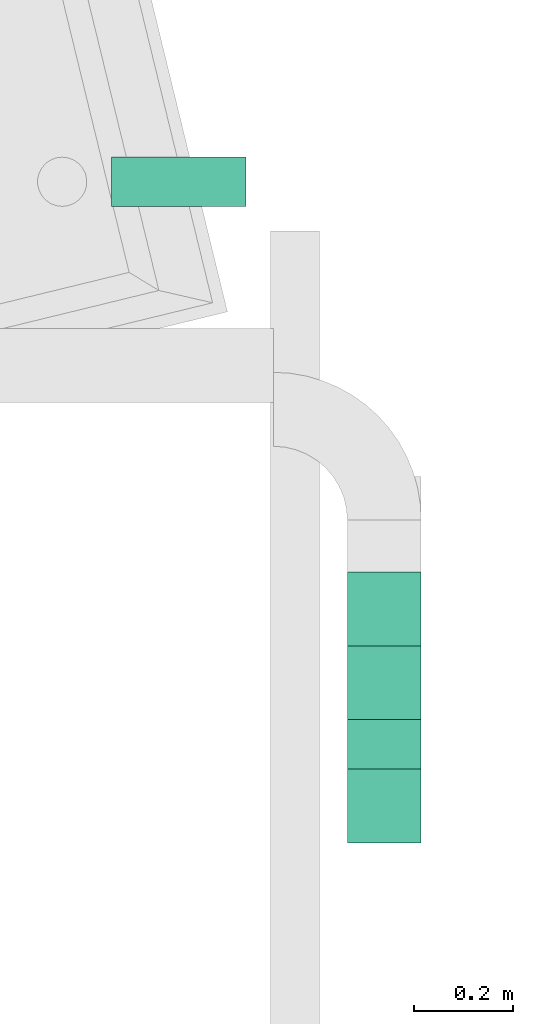
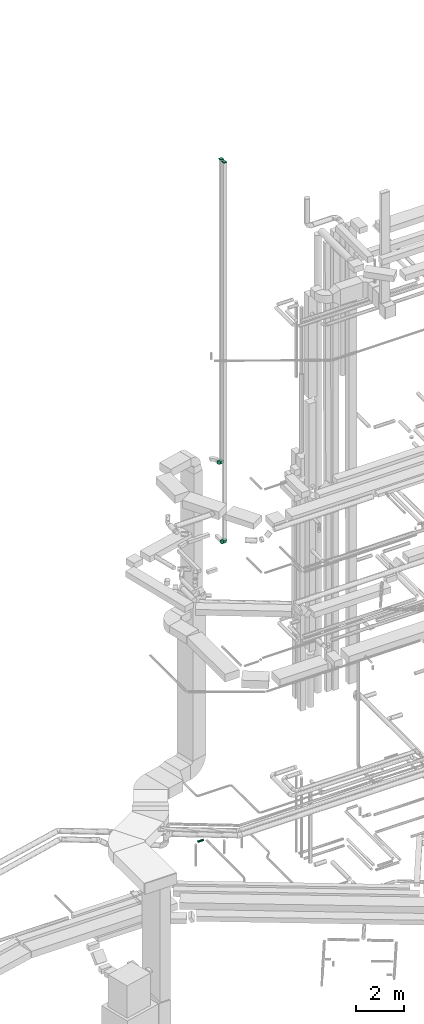
# One storey, part 91 of 337: 4 flow fittings, 1 flow segment.
"""IFC2X3 building model written with IfcOpenShell, lengths in millimetres."""

from ifc_helpers import new_model, entity, si_unit, converted_unit, derived_unit, direction, frame, frame_2d, origin, origin_2d_with_axis, place, context, subcontext, project, spatial, polyline, circle_curve, parameter, trimmed, segment, composite_curve, rectangle, circle, outline, extrude, source, transform, mapped, material, type_object, type_shapes, element, save


model = new_model("IFC2X3")

# Units and contexts
model_context = context("Model", 3, precision=0.01, world=origin(), true_north=direction((6.12303176911189e-17, 1.0)))
body_context = subcontext(model_context, "Body", "Model", "MODEL_VIEW")
ifc_project = project(units=[si_unit("LENGTHUNIT", "METRE", prefix="MILLI"), si_unit("AREAUNIT", "SQUARE_METRE"), si_unit("VOLUMEUNIT", "CUBIC_METRE"), converted_unit("PLANEANGLEUNIT", "DEGREE", entity("IfcRatioMeasure", 0.0174532925199433), si_unit("PLANEANGLEUNIT", "RADIAN"), dimensions=[0, 0, 0, 0, 0, 0, 0]), si_unit("MASSUNIT", "GRAM", prefix="KILO"), derived_unit("MASSDENSITYUNIT", [(si_unit("MASSUNIT", "GRAM", prefix="KILO"), 1), (si_unit("LENGTHUNIT", "METRE"), -3)]), derived_unit("MOMENTOFINERTIAUNIT", [(si_unit("LENGTHUNIT", "METRE"), 4)]), si_unit("TIMEUNIT", "SECOND"), si_unit("FREQUENCYUNIT", "HERTZ"), si_unit("THERMODYNAMICTEMPERATUREUNIT", "DEGREE_CELSIUS"), derived_unit("THERMALTRANSMITTANCEUNIT", [(si_unit("MASSUNIT", "GRAM", prefix="KILO"), 1), (si_unit("THERMODYNAMICTEMPERATUREUNIT", "KELVIN"), -1), (si_unit("TIMEUNIT", "SECOND"), -3)]), derived_unit("VOLUMETRICFLOWRATEUNIT", [(si_unit("LENGTHUNIT", "METRE"), 3), (si_unit("TIMEUNIT", "SECOND"), -1)]), derived_unit("MASSFLOWRATEUNIT", [(si_unit("MASSUNIT", "GRAM", prefix="KILO"), 1), (si_unit("TIMEUNIT", "SECOND"), -1)]), derived_unit("ROTATIONALFREQUENCYUNIT", [(si_unit("TIMEUNIT", "SECOND"), -1)]), si_unit("ELECTRICCURRENTUNIT", "AMPERE"), si_unit("ELECTRICVOLTAGEUNIT", "VOLT"), si_unit("POWERUNIT", "WATT"), si_unit("FORCEUNIT", "NEWTON", prefix="KILO"), si_unit("ILLUMINANCEUNIT", "LUX"), si_unit("LUMINOUSFLUXUNIT", "LUMEN"), si_unit("LUMINOUSINTENSITYUNIT", "CANDELA"), derived_unit("USERDEFINED", [(si_unit("MASSUNIT", "GRAM", prefix="KILO"), -1), (si_unit("LENGTHUNIT", "METRE"), -2), (si_unit("TIMEUNIT", "SECOND"), 3), (si_unit("LUMINOUSFLUXUNIT", "LUMEN"), 1)]), derived_unit("LINEARVELOCITYUNIT", [(si_unit("LENGTHUNIT", "METRE"), 1), (si_unit("TIMEUNIT", "SECOND"), -1)]), si_unit("PRESSUREUNIT", "PASCAL"), derived_unit("USERDEFINED", [(si_unit("LENGTHUNIT", "METRE"), -2), (si_unit("MASSUNIT", "GRAM", prefix="KILO"), 1), (si_unit("TIMEUNIT", "SECOND"), -2)]), derived_unit("LINEARFORCEUNIT", [(si_unit("MASSUNIT", "GRAM", prefix="KILO"), 1), (si_unit("LENGTHUNIT", "METRE"), 1), (si_unit("TIMEUNIT", "SECOND"), -2), (si_unit("LENGTHUNIT", "METRE"), -1)]), derived_unit("PLANARFORCEUNIT", [(si_unit("MASSUNIT", "GRAM", prefix="KILO"), 1), (si_unit("LENGTHUNIT", "METRE"), 1), (si_unit("TIMEUNIT", "SECOND"), -2), (si_unit("LENGTHUNIT", "METRE"), -2)])], contexts=[model_context])

# Site, building, storey
site_placement = place(None, origin())
site = spatial("IfcSite", under=ifc_project, at=site_placement, CompositionType="ELEMENT")
building_placement = place(site_placement, origin())
building = spatial("IfcBuilding", under=site, at=building_placement, CompositionType="ELEMENT")
storey_placement = place(building_placement, origin())
storey = spatial("IfcBuildingStorey", under=building, at=storey_placement, CompositionType="ELEMENT", Elevation=0.0)

# Flow segment
duct_segment_type = type_object("IfcDuctSegmentType", PredefinedType="NOTDEFINED")
flow_segment_placement = place(storey_placement, frame((4771.02, 17357.26, -651.6)))
element("IfcFlowSegment", 1, at=flow_segment_placement, inside=storey, type_object=duct_segment_type, context=body_context, shape_type="SweptSolid", body=[
    extrude(circle(Radius=50.0, at=origin_2d_with_axis()), frame((0.0, 51.6, 51.6), z_axis=(1.0, 0.0, 0.0), x_axis=(0.0, 1.0, 0.0)), (0.0, 0.0, 1.0), 272.689930000015),
])

# Flow fittings
ifc_material = material()
duct_fitting_type_1 = type_object("IfcDuctFittingType", PredefinedType="NOTDEFINED", material=ifc_material)
shared_shape_1 = source(origin(), body_context, "Body", "SweptSolid", [
    extrude(rectangle(XDim=24.9999999999999, YDim=150.0, at=origin_2d_with_axis()), frame((12.5, 0.0, -75.0)), (0.0, 0.0, 1.0), 150.0),
])
type_shapes(duct_fitting_type_1, [shared_shape_1])
for number, where, z_axis, x_axis in (
    (2, (5324.8, 16391.98, 34700.0), (0.0, 1.0, 0.0), (0.0, 0.0, 1.0)),
    (3, (5324.8, 16141.98, 34700.0), (0.0, 1.0, 0.0), (0.0, 0.0, 1.0)),
):
    element("IfcFlowFitting", number, at=place(storey_placement, frame(where, z_axis=z_axis, x_axis=x_axis)), inside=storey, type_object=duct_fitting_type_1, material=ifc_material, context=body_context, shape_type="MappedRepresentation", body=[
        mapped(shared_shape_1, transform((0.0, 0.0, 0.0), scale=1.0)),
    ])
duct_fitting_type_2 = type_object("IfcDuctFittingType", PredefinedType="NOTDEFINED", material=ifc_material)
shared_shape_2 = source(origin(), body_context, "Body", "SweptSolid", [
    extrude(outline(composite_curve([segment(polyline([(-187.5, -112.5), (-37.5, -112.5)]), True, "CONTINUOUS"), segment(trimmed(circle_curve(frame_2d((112.5, -112.5), x_axis=(0.0, 1.0)), 150.0), [parameter(0.0)], [parameter(90.0000000000001)], True, "PARAMETER"), False, "CONTINUOUS"), segment(polyline([(112.5, 37.5), (112.5, 187.5)]), True, "CONTINUOUS"), segment(trimmed(circle_curve(frame_2d((112.5, -112.5), x_axis=(0.0, 1.0)), 300.0), [parameter(0.0)], [parameter(90.0000000000001)], True, "PARAMETER"), True, "CONTINUOUS")], self_intersect=False)), frame((-112.5, 112.5, -75.0), z_axis=(0.0, 0.0, 1.0), x_axis=(-1.0, 0.0, 0.0)), (0.0, 0.0, 1.0), 150.0),
])
type_shapes(duct_fitting_type_2, [shared_shape_2])
for number, where, z_axis, x_axis in (
    (4, (5324.8, 16141.98, 15200.0), (-1.0, 0.0, 0.0), (0.0, -1.0, 0.0)),
    (5, (5324.8, 16391.98, 19100.0), (1.0, 0.0, 0.0), (0.0, 0.0, -1.0)),
):
    element("IfcFlowFitting", number, at=place(storey_placement, frame(where, z_axis=z_axis, x_axis=x_axis)), inside=storey, type_object=duct_fitting_type_2, material=ifc_material, context=body_context, shape_type="MappedRepresentation", body=[
        mapped(shared_shape_2, transform((0.0, 0.0, 0.0), scale=1.0)),
    ])

save(model, "model.ifc")
